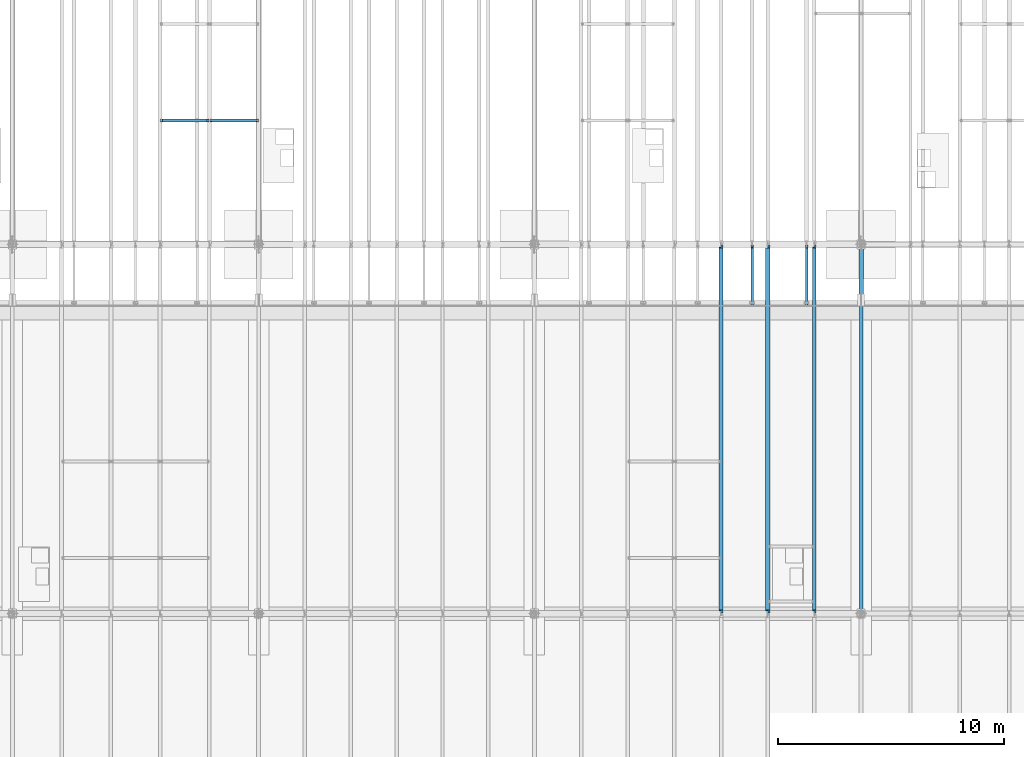
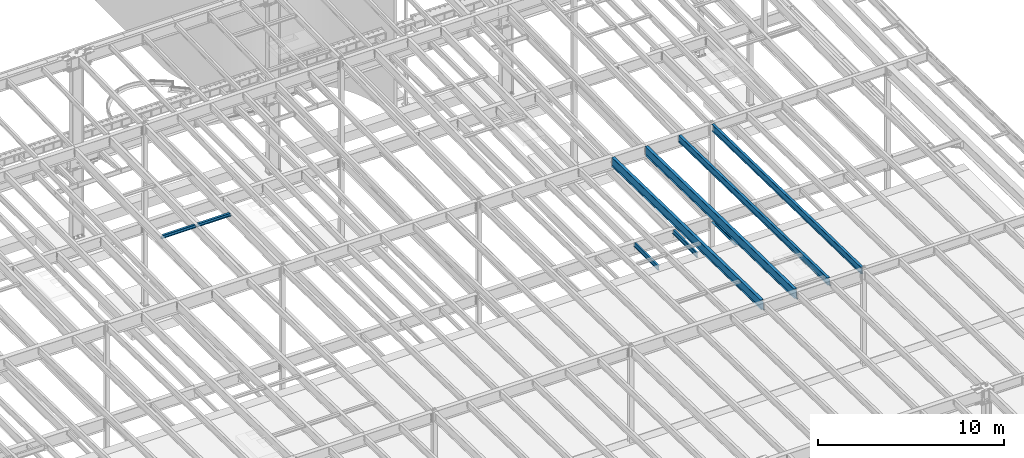
# One storey, part 1103 of 1763: 9 beams, 9 elements without a shape of their own.
"""IFC2X3 building model written with IfcOpenShell, lengths in millimetres."""

from ifc_helpers import new_model, si_unit, frame, origin_with_axes, place, context, subcontext, project, spatial, faceted_brep, material, type_object, element, aggregate, save


model = new_model("IFC2X3")

# Units and contexts
model_context = context("Model", 3, precision=1e-05, world=origin_with_axes())
body_context = subcontext(model_context, "Body", "Model", "MODEL_VIEW")
ifc_project = project(units=[si_unit("LENGTHUNIT", "METRE", prefix="MILLI"), si_unit("AREAUNIT", "SQUARE_METRE"), si_unit("VOLUMEUNIT", "CUBIC_METRE"), si_unit("MASSUNIT", "GRAM", prefix="KILO"), si_unit("TIMEUNIT", "SECOND"), si_unit("PLANEANGLEUNIT", "RADIAN"), si_unit("SOLIDANGLEUNIT", "STERADIAN"), si_unit("THERMODYNAMICTEMPERATUREUNIT", "DEGREE_CELSIUS"), si_unit("LUMINOUSINTENSITYUNIT", "LUMEN")], contexts=[model_context])

# Site, building, storey
site_placement = place(None, origin_with_axes())
site = spatial("IfcSite", under=ifc_project, at=site_placement, CompositionType="ELEMENT")
building_placement = place(site_placement, origin_with_axes())
building = spatial("IfcBuilding", under=site, at=building_placement, Name="Undefined", CompositionType="ELEMENT")
storey_placement = place(building_placement, origin_with_axes())
storey = spatial("IfcBuildingStorey", under=building, at=storey_placement, Name="Undefined", CompositionType="ELEMENT", Elevation=0.0)

# Assembly, beam
assembly_1_placement = place(storey_placement, origin_with_axes())
assembly_1 = element("IfcElementAssembly", 1, at=assembly_1_placement, inside=storey, Name="BEAM", AssemblyPlace="NOTDEFINED", PredefinedType="RIGID_FRAME")
ifc_material = material(Name="STEEL/A992")
beam_type_1 = type_object("IfcBeamType", Name="W8X18", PredefinedType="NOTDEFINED")
beam_1_placement = place(assembly_1_placement, frame((-65953.0772736983, 35509.2, 11300.6242220873), z_axis=(0.0, 0.0, 1.0), x_axis=(1.0, 0.0, 0.0)))
beam_1 = element("IfcBeam", 2, at=beam_1_placement, type_object=beam_type_1, material=ifc_material, Name="BEAM", ObjectType="W8X18", context=body_context, shape_type="Brep", body=[
    faceted_brep([(2083.02724382307, -3.17499999999927, 68.5472455037416), (2083.02724382307, 3.17499999999927, 68.5472455037416), (2082.16625903222, 3.17499999999927, 69.8358003002977), (2082.16625903222, -3.17499999999927, 69.8358003002977), (2087.14742029124, -3.17499999999927, 65.7942316032641), (2087.14742029124, 3.17499999999927, 65.7942316032641), (2092.00749980928, -3.17499999999927, 64.8275016806765), (2092.00749980928, 3.17499999999927, 64.8275016806765), (2161.85750000001, -3.17499999999927, 64.8275016806765), (2161.85750000001, 3.17499999999927, 64.8275016806765), (2081.43974687482, -3.17499999999927, 70.3212402040699), (2081.43974687482, 3.17499999999927, 70.3212402040699), (2078.68673297434, 3.17499999999927, 74.4414166722236), (2078.68673297434, -3.17499999999927, 74.4414166722236), (2077.72000305176, 3.17499999999927, 79.30149619027), (2077.72000305176, -3.17499999999927, 79.30149619027), (101.599996948244, 3.17500000000018, 95.25), (101.599996948244, 66.6750000000002, 95.25), (2077.72000305177, 66.6749999999993, 95.25), (2077.72000305177, 3.17499999999927, 95.25), (101.599996948244, -66.6750000000002, 103.1875), (101.599996948244, -66.6750000000002, 95.25), (2077.72000305177, -66.6749999999993, 95.25), (2077.72000305177, -66.6749999999993, 103.1875), (101.599996948244, 66.6750000000002, 103.1875), (2077.72000305177, 66.6749999999993, 103.1875), (2077.72000305177, -3.17499999999927, 95.25), (101.599996948244, -3.17500000000018, 95.25), (101.599996948236, 3.17499999999927, 79.301496189446), (101.599996948236, -3.17499999999927, 79.301496189446), (100.633267025652, 3.17499999999927, 74.4414166713996), (100.633267025652, -3.17499999999927, 74.4414166713996), (97.8802531251713, 3.17499999999927, 70.3212402032459), (97.8802531251713, -3.17499999999927, 70.3212402032459), (97.153740969894, 3.17499999999927, 69.8358003008998), (97.153740969894, -3.17499999999927, 69.8358003008998), (96.2927561769247, 3.17500000000018, 68.5472454911378), (96.2927561769247, -3.17500000000018, 68.5472454911378), (92.1725797087711, 3.17500000000018, 65.7942315906603), (92.1725797087711, -3.17500000000018, 65.7942315906603), (87.3125001907247, 3.17500000000018, 64.8275016680727), (87.3125001907247, -3.17500000000018, 64.8275016680727), (17.4624999999905, 3.17500000000018, 64.8275016680727), (17.4624999999905, -3.17500000000018, 64.8275016680727), (17.4624999999905, 3.17500000000018, -95.25), (17.4624999999905, 66.6750000000002, -95.25), (17.4624999999905, 66.6750000000002, -103.1875), (17.4624999999905, -66.6750000000002, -103.1875), (17.4624999999905, -66.6750000000002, -95.25), (17.4624999999905, -3.17500000000018, -95.25), (2161.85750000001, 3.17499999999927, -95.25), (2161.85750000001, 66.6749999999993, -95.25), (2161.85750000001, 66.6749999999993, -103.1875), (2161.85750000001, -66.6749999999993, -103.1875), (2161.85750000001, -66.6749999999993, -95.25), (2161.85750000001, -3.17499999999927, -95.25)], [[[0, 1, 2, 3]], [[4, 5, 1, 0]], [[6, 7, 5, 4]], [[8, 9, 7, 6]], [[10, 11, 12, 13]], [[13, 12, 14, 15]], [[16, 17, 18, 19]], [[20, 21, 22, 23]], [[24, 20, 23, 25]], [[17, 24, 25, 18]], [[23, 22, 26, 15, 14, 19, 18, 25]], [[21, 27, 26, 22]], [[20, 24, 17, 16, 28, 29, 27, 21]], [[29, 28, 30, 31]], [[31, 30, 32, 33]], [[33, 32, 34, 35]], [[35, 34, 36, 37]], [[37, 36, 38, 39]], [[39, 38, 40, 41]], [[41, 40, 42, 43]], [[44, 45, 46, 47, 48, 49, 43, 42]], [[45, 44, 50, 51]], [[46, 45, 51, 52]], [[47, 46, 52, 53]], [[48, 47, 53, 54]], [[49, 48, 54, 55]], [[4, 0, 3, 10, 13, 15, 26, 27, 29, 31, 33, 35, 37, 39, 41, 43, 49, 55, 8, 6]], [[11, 10, 3, 2]], [[50, 44, 42, 40, 38, 36, 34, 32, 30, 28, 16, 19, 14, 12, 11, 2, 1, 5, 7, 9]], [[55, 54, 53, 52, 51, 50, 9, 8]]]),
])
aggregate(assembly_1, [beam_1])

assembly_2_placement = place(storey_placement, origin_with_axes())
assembly_2 = element("IfcElementAssembly", 3, at=assembly_2_placement, inside=storey, Name="BEAM", AssemblyPlace="NOTDEFINED", PredefinedType="RIGID_FRAME")
beam_2_placement = place(assembly_2_placement, frame((-63773.7572736983, 35509.2, 11300.6242220873), z_axis=(0.0, 0.0, 1.0), x_axis=(1.0, 0.0, 0.0)))
beam_2 = element("IfcBeam", 4, at=beam_2_placement, type_object=beam_type_1, material=ifc_material, Name="BEAM", ObjectType="W8X18", context=body_context, shape_type="Brep", body=[
    faceted_brep([(2083.02724382307, -3.17499999999927, 68.5472455037416), (2083.02724382307, 3.17499999999927, 68.5472455037416), (2082.16625903222, 3.17499999999927, 69.8358003002977), (2082.16625903222, -3.17499999999927, 69.8358003002977), (2087.14742029124, -3.17499999999927, 65.7942316032641), (2087.14742029124, 3.17499999999927, 65.7942316032641), (2092.00749980928, -3.17499999999927, 64.8275016806765), (2092.00749980928, 3.17499999999927, 64.8275016806765), (2161.85750000001, -3.17499999999927, 64.8275016806765), (2161.85750000001, 3.17499999999927, 64.8275016806765), (2081.43974687482, -3.17499999999927, 70.3212402040699), (2081.43974687482, 3.17499999999927, 70.3212402040699), (2078.68673297434, 3.17499999999927, 74.4414166722236), (2078.68673297434, -3.17499999999927, 74.4414166722236), (2077.72000305176, 3.17499999999927, 79.30149619027), (2077.72000305176, -3.17499999999927, 79.30149619027), (101.599996948244, 3.17500000000018, 95.25), (101.599996948244, 66.6750000000002, 95.25), (2077.72000305177, 66.6749999999993, 95.25), (2077.72000305177, 3.17499999999927, 95.25), (101.599996948244, -66.6750000000002, 103.1875), (101.599996948244, -66.6750000000002, 95.25), (2077.72000305177, -66.6749999999993, 95.25), (2077.72000305177, -66.6749999999993, 103.1875), (101.599996948244, 66.6750000000002, 103.1875), (2077.72000305177, 66.6749999999993, 103.1875), (2077.72000305177, -3.17499999999927, 95.25), (101.599996948244, -3.17500000000018, 95.25), (101.599996948236, 3.17499999999927, 79.301496189446), (101.599996948236, -3.17499999999927, 79.301496189446), (100.633267025652, 3.17499999999927, 74.4414166713996), (100.633267025652, -3.17499999999927, 74.4414166713996), (97.8802531251713, 3.17499999999927, 70.3212402032459), (97.8802531251713, -3.17499999999927, 70.3212402032459), (97.153740969894, 3.17499999999927, 69.8358003008998), (97.153740969894, -3.17499999999927, 69.8358003008998), (96.2927561769247, 3.17500000000018, 68.5472454911378), (96.2927561769247, -3.17500000000018, 68.5472454911378), (92.1725797087711, 3.17500000000018, 65.7942315906603), (92.1725797087711, -3.17500000000018, 65.7942315906603), (87.3125001907247, 3.17500000000018, 64.8275016680727), (87.3125001907247, -3.17500000000018, 64.8275016680727), (17.4624999999905, 3.17500000000018, 64.8275016680727), (17.4624999999905, -3.17500000000018, 64.8275016680727), (17.4624999999905, 3.17500000000018, -95.25), (17.4624999999905, 66.6750000000002, -95.25), (17.4624999999905, 66.6750000000002, -103.1875), (17.4624999999905, -66.6750000000002, -103.1875), (17.4624999999905, -66.6750000000002, -95.25), (17.4624999999905, -3.17500000000018, -95.25), (2161.85750000001, 3.17499999999927, -95.25), (2161.85750000001, 66.6749999999993, -95.25), (2161.85750000001, 66.6749999999993, -103.1875), (2161.85750000001, -66.6749999999993, -103.1875), (2161.85750000001, -66.6749999999993, -95.25), (2161.85750000001, -3.17499999999927, -95.25)], [[[0, 1, 2, 3]], [[4, 5, 1, 0]], [[6, 7, 5, 4]], [[8, 9, 7, 6]], [[10, 11, 12, 13]], [[13, 12, 14, 15]], [[16, 17, 18, 19]], [[20, 21, 22, 23]], [[24, 20, 23, 25]], [[17, 24, 25, 18]], [[23, 22, 26, 15, 14, 19, 18, 25]], [[21, 27, 26, 22]], [[20, 24, 17, 16, 28, 29, 27, 21]], [[29, 28, 30, 31]], [[31, 30, 32, 33]], [[33, 32, 34, 35]], [[35, 34, 36, 37]], [[37, 36, 38, 39]], [[39, 38, 40, 41]], [[41, 40, 42, 43]], [[44, 45, 46, 47, 48, 49, 43, 42]], [[45, 44, 50, 51]], [[46, 45, 51, 52]], [[47, 46, 52, 53]], [[48, 47, 53, 54]], [[49, 48, 54, 55]], [[4, 0, 3, 10, 13, 15, 26, 27, 29, 31, 33, 35, 37, 39, 41, 43, 49, 55, 8, 6]], [[11, 10, 3, 2]], [[50, 44, 42, 40, 38, 36, 34, 32, 30, 28, 16, 19, 14, 12, 11, 2, 1, 5, 7, 9]], [[55, 54, 53, 52, 51, 50, 9, 8]]]),
])
aggregate(assembly_2, [beam_2])

assembly_3_placement = place(storey_placement, origin_with_axes())
assembly_3 = element("IfcElementAssembly", 5, at=assembly_3_placement, inside=storey, Name="BEAM", AssemblyPlace="NOTDEFINED", PredefinedType="RIGID_FRAME")
beam_type_2 = type_object("IfcBeamType", Name="W12X16", PredefinedType="NOTDEFINED")
beam_3_placement = place(assembly_3_placement, frame((-37358.603940365, 27279.6, 5041.9), z_axis=(0.0, 0.0, 1.0), x_axis=(0.0, 1.0, 0.0)))
beam_3 = element("IfcBeam", 6, at=beam_3_placement, type_object=beam_type_2, material=ifc_material, Name="BEAM", ObjectType="W12X16", context=body_context, shape_type="Brep", body=[
    faceted_brep([(63.5000000000036, -3.17499999999927, -146.05), (63.5000000000036, -50.7999999999993, -146.05), (2723.35625, -50.8000000000029, -146.05), (2723.35625, -3.17500000000291, -146.05), (63.5000000000036, -50.7999999999993, -152.4), (2723.35625, -50.8000000000029, -152.4), (63.5000000000036, 50.7999999999993, -152.4), (2723.35625, 50.8000000000029, -152.4), (63.5000000000036, 50.7999999999993, -146.05), (63.5000000000036, 3.17499999999927, -146.05), (2723.35625, 3.17500000000291, -146.05), (2723.35625, 50.8000000000029, -146.05), (2723.35625, 3.17500000000291, 120.390001678466), (2723.35625, -3.17500000000291, 120.390001678466), (63.5000000000036, -3.17499999999927, 146.05), (63.5000000000036, -50.7999999999993, 146.05), (63.5000000000036, -50.7999999999993, 152.4), (63.5000000000036, 50.7999999999993, 152.4), (63.5000000000036, 50.7999999999993, 146.05), (63.5000000000036, 3.17499999999927, 146.05), (2583.65625, 50.8000000000029, 146.05), (2583.65625, 3.17500000000291, 146.05), (2583.65625, 3.17500000000291, 133.090001487732), (2584.62297992259, 3.17500000000291, 128.229921969686), (2587.37599382307, 3.17500000000291, 124.109745501532), (2591.49617029122, 3.17500000000291, 121.356731601054), (2596.35624980927, 3.17500000000291, 120.390001678466), (2584.62297992259, -3.17500000000291, 128.229921969686), (2583.65625, -3.17500000000291, 133.090001487732), (2587.37599382307, -3.17500000000291, 124.109745501532), (2591.49617029122, -3.17500000000291, 121.356731601054), (2596.35624980927, -3.17500000000291, 120.390001678466), (2583.65625, -3.17500000000291, 146.05), (2583.65625, -50.8000000000029, 146.05), (2583.65625, -50.8000000000029, 152.4), (2583.65625, 50.8000000000029, 152.4)], [[[0, 1, 2, 3]], [[1, 4, 5, 2]], [[4, 6, 7, 5]], [[8, 9, 10, 11]], [[3, 2, 5, 7, 11, 10, 12, 13]], [[6, 8, 11, 7]], [[4, 1, 0, 14, 15, 16, 17, 18, 19, 9, 8, 6]], [[19, 18, 20, 21]], [[10, 9, 19, 21, 22, 23, 24, 25, 26, 12]], [[27, 23, 22, 28]], [[29, 24, 23, 27]], [[30, 25, 24, 29]], [[31, 26, 25, 30]], [[13, 12, 26, 31]], [[30, 29, 27, 28, 32, 14, 0, 3, 13, 31]], [[15, 14, 32, 33]], [[16, 15, 33, 34]], [[17, 16, 34, 35]], [[18, 17, 35, 20]], [[34, 33, 32, 28, 22, 21, 20, 35]]]),
])
aggregate(assembly_3, [beam_3])

assembly_4_placement = place(storey_placement, origin_with_axes())
assembly_4 = element("IfcElementAssembly", 7, at=assembly_4_placement, inside=storey, Name="BEAM", AssemblyPlace="NOTDEFINED", PredefinedType="RIGID_FRAME")
beam_4_placement = place(assembly_4_placement, frame((-39767.3706070317, 27279.6, 5041.9), z_axis=(0.0, 0.0, 1.0), x_axis=(0.0, 1.0, 0.0)))
beam_4 = element("IfcBeam", 8, at=beam_4_placement, type_object=beam_type_2, material=ifc_material, Name="BEAM", ObjectType="W12X16", context=body_context, shape_type="Brep", body=[
    faceted_brep([(63.5000000000036, -3.17499999999927, -146.05), (63.5000000000036, -50.7999999999993, -146.05), (2723.35625, -50.8000000000029, -146.05), (2723.35625, -3.17500000000291, -146.05), (63.5000000000036, -50.7999999999993, -152.4), (2723.35625, -50.8000000000029, -152.4), (63.5000000000036, 50.7999999999993, -152.4), (2723.35625, 50.8000000000029, -152.4), (63.5000000000036, 50.7999999999993, -146.05), (63.5000000000036, 3.17499999999927, -146.05), (2723.35625, 3.17500000000291, -146.05), (2723.35625, 50.8000000000029, -146.05), (2723.35625, 3.17500000000291, 120.390001678466), (2723.35625, -3.17500000000291, 120.390001678466), (63.5000000000036, -3.17499999999927, 146.05), (63.5000000000036, -50.7999999999993, 146.05), (63.5000000000036, -50.7999999999993, 152.4), (63.5000000000036, 50.7999999999993, 152.4), (63.5000000000036, 50.7999999999993, 146.05), (63.5000000000036, 3.17499999999927, 146.05), (2583.65625, 50.8000000000029, 146.05), (2583.65625, 3.17500000000291, 146.05), (2583.65625, 3.17500000000291, 133.090001487732), (2584.62297992259, 3.17500000000291, 128.229921969686), (2587.37599382307, 3.17500000000291, 124.109745501532), (2591.49617029122, 3.17500000000291, 121.356731601054), (2596.35624980927, 3.17500000000291, 120.390001678466), (2584.62297992259, -3.17500000000291, 128.229921969686), (2583.65625, -3.17500000000291, 133.090001487732), (2587.37599382307, -3.17500000000291, 124.109745501532), (2591.49617029122, -3.17500000000291, 121.356731601054), (2596.35624980927, -3.17500000000291, 120.390001678466), (2583.65625, -3.17500000000291, 146.05), (2583.65625, -50.8000000000029, 146.05), (2583.65625, -50.8000000000029, 152.4), (2583.65625, 50.8000000000029, 152.4)], [[[0, 1, 2, 3]], [[1, 4, 5, 2]], [[4, 6, 7, 5]], [[8, 9, 10, 11]], [[3, 2, 5, 7, 11, 10, 12, 13]], [[6, 8, 11, 7]], [[4, 1, 0, 14, 15, 16, 17, 18, 19, 9, 8, 6]], [[19, 18, 20, 21]], [[10, 9, 19, 21, 22, 23, 24, 25, 26, 12]], [[27, 23, 22, 28]], [[29, 24, 23, 27]], [[30, 25, 24, 29]], [[31, 26, 25, 30]], [[13, 12, 26, 31]], [[30, 29, 27, 28, 32, 14, 0, 3, 13, 31]], [[15, 14, 32, 33]], [[16, 15, 33, 34]], [[17, 16, 34, 35]], [[18, 17, 35, 20]], [[34, 33, 32, 28, 22, 21, 20, 35]]]),
])
aggregate(assembly_4, [beam_4])

assembly_5_placement = place(storey_placement, origin_with_axes())
assembly_5 = element("IfcElementAssembly", 9, at=assembly_5_placement, inside=storey, Name="BEAM", AssemblyPlace="NOTDEFINED", PredefinedType="RIGID_FRAME")
beam_type_3 = type_object("IfcBeamType", Name="W18X40", PredefinedType="NOTDEFINED")
beam_5_placement = place(assembly_5_placement, frame((-37014.4944165555, 13685.8551307141, 11404.7768219843), z_axis=(0.0, 0.0209013539966291, 0.999781542838788), x_axis=(0.0, 0.999781542776098, -0.0209013569953182)))
beam_5 = element("IfcBeam", 10, at=beam_5_placement, type_object=beam_type_3, material=ifc_material, Name="BEAM", ObjectType="W18X40", context=body_context, shape_type="Brep", body=[
    faceted_brep([(132.544002095614, 4.26866853534011, -214.312499999889), (132.544002095599, 4.26882839031896, -227.012499999888), (29.339897632873, 4.26882972748717, -227.01250000019), (29.0743924101943, 4.26863241521642, -214.31250000018), (132.543992672528, 76.1999999999971, -214.312499999889), (132.543992672539, 76.1999999999971, -227.012499999888), (164.293992016979, -3.96875, 195.002501487832), (164.293992016979, 3.96875, 195.002501487832), (163.327262094397, 3.96875, 190.142421969791), (163.327262094397, -3.96875, 190.142421969791), (160.574248193921, 3.96875, 186.022245501637), (160.574248193921, -3.96875, 186.022245501637), (156.454071725771, 3.96875, 183.269231601158), (156.454071725771, -3.96875, 183.269231601158), (151.593992207727, 3.96875, 182.302501678567), (151.593992207727, -3.96875, 182.302501678567), (20.7827897637508, 3.96875, 182.30250167849), (20.7827897637508, -3.96875, 182.30250167849), (29.0743924101943, -3.96875, -214.31250000018), (16325.1468877506, -3.96875, -214.312499990354), (16316.8552846474, -3.96875, 182.302501822591), (16187.3164867041, -3.96875, 182.302501822514), (16182.456407186, -3.96875, 183.269231745098), (16178.3362307179, -3.96875, 186.022245645572), (16175.5832168174, -3.96875, 190.142422113722), (16174.6164868948, -3.96875, 195.002501631765), (16174.6164868948, -3.96875, 214.312500009495), (164.29399201697, -3.96875, 214.312500000067), (29.0743924101943, -76.1999999999971, -214.31250000018), (16325.1468877506, -76.1999999999971, -214.312499990354), (29.339897632873, -76.1999999999971, -227.01250000019), (16325.412392986, -76.1999999999971, -227.012499990351), (16225.4164838328, 4.26882845565706, -214.312499990412), (16225.4164838328, 4.26866860519658, -227.012499990411), (16225.4164773588, 76.1999999999971, -227.012499990409), (16225.4164773587, 76.1999999999971, -214.312499990414), (16325.412392986, 4.2686776052069, -227.012499990351), (16325.1468877506, 4.26883743175858, -214.312499990354), (16325.1468877506, 3.96875, -214.312499990354), (16316.8552846474, 3.96875, 182.302501822591), (16187.3164867041, 3.96875, 182.302501822514), (16182.456407186, 3.96875, 183.269231745098), (16178.3362307179, 3.96875, 186.022245645572), (16175.5832168174, 3.96875, 190.142422113722), (16174.6164868948, 3.96875, 195.002501631765), (16174.6164868948, -76.1999999999971, 227.01250000949), (16174.6164868948, -76.1999999999971, 214.312500009495), (16174.6164868948, 3.96875, 214.312500009495), (16174.6164868948, 76.1999999999971, 214.312500009495), (16174.6164868948, 76.1999999999971, 227.01250000949), (164.29399201697, 3.96875, 214.312500000067), (164.29399201697, 76.1999999999971, 214.312500000067), (164.293992016963, 76.1999999999971, 227.012500000064), (164.293992016963, -76.1999999999971, 227.012500000064), (164.29399201697, -76.1999999999971, 214.312500000067), (29.0743924101943, 3.96875, -214.31250000018)], [[[0, 1, 2, 3]], [[4, 5, 1, 0]], [[6, 7, 8, 9]], [[9, 8, 10, 11]], [[11, 10, 12, 13]], [[13, 12, 14, 15]], [[15, 14, 16, 17]], [[9, 11, 13, 15, 17, 18, 19, 20, 21, 22, 23, 24, 25, 26, 27, 6]], [[18, 28, 29, 19]], [[28, 30, 31, 29]], [[32, 33, 34, 35]], [[36, 33, 32, 37]], [[38, 39, 20, 19, 29, 31, 36, 37]], [[20, 39, 40, 21]], [[21, 40, 41, 22]], [[22, 41, 42, 23]], [[23, 42, 43, 24]], [[24, 43, 44, 25]], [[45, 46, 26, 25, 44, 47, 48, 49]], [[48, 47, 50, 51]], [[49, 48, 51, 52]], [[45, 49, 52, 53]], [[46, 45, 53, 54]], [[26, 46, 54, 27]], [[53, 52, 51, 50, 7, 6, 27, 54]], [[47, 44, 43, 42, 41, 40, 39, 38, 55, 16, 14, 12, 10, 8, 7, 50]], [[30, 28, 18, 17, 16, 55, 3, 2]], [[34, 33, 36, 31, 30, 2, 1, 5]], [[35, 34, 5, 4]], [[55, 38, 37, 32, 35, 4, 0, 3]]]),
])
aggregate(assembly_5, [beam_5])

assembly_6_placement = place(storey_placement, origin_with_axes())
assembly_6 = element("IfcElementAssembly", 11, at=assembly_6_placement, inside=storey, Name="BEAM", AssemblyPlace="NOTDEFINED", PredefinedType="RIGID_FRAME")
beam_6_placement = place(assembly_6_placement, frame((-34949.8372736984, 13685.8548242898, 11404.7988868453), z_axis=(0.0, 0.0209027059910768, 0.999781514573185), x_axis=(0.0, 0.999781514573184, -0.0209027059910808)))
beam_6 = element("IfcBeam", 12, at=beam_6_placement, type_object=beam_type_3, material=ifc_material, Name="BEAM", ObjectType="W18X40", context=body_context, shape_type="Brep", body=[
    faceted_brep([(149.22295429465, -76.1999999999971, -227.012499999968), (149.22295429465, 76.1999999999971, -227.012499999968), (16200.7674828319, 76.1999999999971, -227.012500012277), (16200.7674828319, -76.1999999999971, -227.012500012277), (148.957431915793, -76.1999999999971, -214.312499999975), (148.957431915793, -3.96875, -214.312499999975), (139.996051629378, -3.96875, 214.31249999976), (139.996051629378, -76.1999999999971, 214.31249999976), (139.730529250521, -76.1999999999971, 227.012499999752), (139.730529250521, 76.1999999999971, 227.012499999752), (139.996051629378, 76.1999999999971, 214.31249999976), (139.996051629378, 3.96875, 214.31249999976), (148.957431915793, 3.96875, -214.312499999975), (148.957431915793, 76.1999999999971, -214.312499999975), (16200.501960453, -76.1999999999971, -214.312500012285), (16200.501960453, -3.96875, -214.312500012285), (16191.5405801666, -3.96875, 214.312499987449), (16191.5405801666, -76.1999999999971, 214.312499987449), (16191.2750577878, -76.1999999999971, 227.012499987441), (16191.2750577878, 76.1999999999971, 227.012499987441), (16191.5405801666, 76.1999999999971, 214.312499987449), (16191.5405801666, 3.96875, 214.312499987449), (16200.501960453, 3.96875, -214.312500012285), (16200.501960453, 76.1999999999971, -214.312500012285)], [[[0, 1, 2, 3]], [[0, 4, 5, 6, 7, 8, 9, 10, 11, 12, 13, 1]], [[5, 4, 14, 15]], [[6, 5, 15, 16]], [[7, 6, 16, 17]], [[8, 7, 17, 18]], [[9, 8, 18, 19]], [[10, 9, 19, 20]], [[11, 10, 20, 21]], [[12, 11, 21, 22]], [[13, 12, 22, 23]], [[1, 13, 23, 2]], [[22, 21, 20, 19, 18, 17, 16, 15, 14, 3, 2, 23]], [[4, 0, 3, 14]]]),
])
aggregate(assembly_6, [beam_6])

assembly_7_placement = place(storey_placement, origin_with_axes())
assembly_7 = element("IfcElementAssembly", 13, at=assembly_7_placement, inside=storey, Name="BEAM", AssemblyPlace="NOTDEFINED", PredefinedType="RIGID_FRAME")
beam_type_4 = type_object("IfcBeamType", Name="W24X55", PredefinedType="NOTDEFINED")
beam_7_placement = place(assembly_7_placement, frame((-41143.8087022698, 13684.3288091446, 11331.7677748226), z_axis=(0.0, 0.0209013539966291, 0.999781542838788), x_axis=(0.0, 0.999781542776098, -0.0209013569953182)))
beam_7 = element("IfcBeam", 14, at=beam_7_placement, type_object=beam_type_4, material=ifc_material, Name="BEAM", ObjectType="W24X55", context=body_context, shape_type="Brep", body=[
    faceted_brep([(134.070659533922, 5.06239015424217, -287.337499999876), (134.070659533891, 5.06260677571845, -300.037499999875), (32.3932082812735, 5.06259254094039, -300.037499999935), (32.127703045895, 5.06237588229124, -287.337499999938), (134.070647796716, 88.9000000000015, -287.337499999878), (134.070647796721, 88.9000000000015, -300.037499999875), (165.820647095326, -4.76249999999709, 268.027501487795), (165.820647095326, 4.76249999999709, 268.027501487795), (164.853917172741, 4.76249999999709, 263.167421969751), (164.853917172741, -4.76249999999709, 263.167421969751), (162.100903272267, 4.76249999999709, 259.047245501597), (162.100903272267, -4.76249999999709, 259.047245501597), (157.980726804117, 4.76249999999709, 256.294231601119), (157.980726804117, -4.76249999999709, 256.294231601119), (153.120647286072, 4.76249999999709, 255.327501678528), (153.120647286072, -4.76249999999709, 255.327501678528), (20.7827897386833, 4.76249999999709, 255.32750167845), (20.7827897386833, -4.76249999999709, 255.32750167845), (32.127703045895, -4.76249999999709, -287.337499999938), (16328.2001979324, -4.76249999999709, -287.337499990341), (16316.8552846223, -4.76249999999709, 255.32750182257), (16188.8431417824, -4.76249999999709, 255.327501822494), (16183.9830622644, -4.76249999999709, 256.29423174508), (16179.8628857962, -4.76249999999709, 259.047245645552), (16177.1098718957, -4.76249999999709, 263.167422113704), (16176.1431419731, -4.76249999999709, 268.027501631745), (16176.1431419731, -4.76249999999709, 287.337500009484), (165.820647095314, -4.76249999999709, 287.337500000056), (32.127703045895, -88.9000000000015, -287.337499999938), (16328.2001979324, -88.9000000000015, -287.337499990341), (32.3932082812735, -88.9000000000015, -300.037499999935), (16328.4657031678, -88.9000000000015, -300.037499990338), (16226.943138802, 5.06260682461289, -287.337499990401), (16226.943138802, 5.06239020794601, -300.037499990398), (16226.9431320109, 88.9000000000015, -300.037499990398), (16226.9431320109, 88.9000000000015, -287.337499990401), (16299.8693796049, 5.06250000000728, -287.337499990357), (16228.1976692106, 5.06250000000728, -288.83586332407), (16228.1663445405, 5.06250000000728, -287.337499990399), (16328.4657031678, 5.06239843160438, -300.037499990338), (16328.2001979324, 5.06261502674897, -287.337499990341), (16328.2001979324, 4.76249999999709, -287.337499990341), (16316.8552846223, 4.76249999999709, 255.32750182257), (16188.8431417824, 4.76249999999709, 255.327501822494), (16183.9830622644, 4.76249999999709, 256.29423174508), (16179.8628857962, 4.76249999999709, 259.047245645552), (16177.1098718957, 4.76249999999709, 263.167422113704), (16176.1431419731, 4.76249999999709, 268.027501631745), (16176.1431419731, -88.9000000000015, 300.037500009483), (16176.1431419731, -88.9000000000015, 287.337500009484), (16176.1431419731, 4.76249999999709, 287.337500009484), (16176.1431419731, 88.9000000000015, 287.337500009484), (16176.1431419731, 88.9000000000015, 300.037500009483), (165.820647095314, 4.76249999999709, 287.337500000056), (165.820647095314, 88.9000000000015, 287.337500000056), (165.820647095305, 88.9000000000015, 300.037500000057), (165.820647095305, -88.9000000000015, 300.037500000057), (165.820647095314, -88.9000000000015, 287.337500000056), (32.127703045895, 4.76249999999709, -287.337499999938)], [[[0, 1, 2, 3]], [[4, 5, 1, 0]], [[6, 7, 8, 9]], [[9, 8, 10, 11]], [[11, 10, 12, 13]], [[13, 12, 14, 15]], [[15, 14, 16, 17]], [[9, 11, 13, 15, 17, 18, 19, 20, 21, 22, 23, 24, 25, 26, 27, 6]], [[18, 28, 29, 19]], [[28, 30, 31, 29]], [[32, 33, 34, 35]], [[36, 37, 38]], [[39, 33, 32, 38, 37, 36, 40]], [[41, 42, 20, 19, 29, 31, 39, 40]], [[20, 42, 43, 21]], [[21, 43, 44, 22]], [[22, 44, 45, 23]], [[23, 45, 46, 24]], [[24, 46, 47, 25]], [[48, 49, 26, 25, 47, 50, 51, 52]], [[51, 50, 53, 54]], [[52, 51, 54, 55]], [[48, 52, 55, 56]], [[49, 48, 56, 57]], [[26, 49, 57, 27]], [[56, 55, 54, 53, 7, 6, 27, 57]], [[50, 47, 46, 45, 44, 43, 42, 41, 58, 16, 14, 12, 10, 8, 7, 53]], [[30, 28, 18, 17, 16, 58, 3, 2]], [[34, 33, 39, 31, 30, 2, 1, 5]], [[35, 34, 5, 4]], [[58, 41, 40, 36, 38, 32, 35, 4, 0, 3]]]),
])
aggregate(assembly_7, [beam_7])

assembly_8_placement = place(storey_placement, origin_with_axes())
assembly_8 = element("IfcElementAssembly", 15, at=assembly_8_placement, inside=storey, Name="BEAM", AssemblyPlace="NOTDEFINED", PredefinedType="RIGID_FRAME")
beam_8_placement = place(assembly_8_placement, frame((-39079.1515594127, 13684.3288091094, 11331.7677748225), z_axis=(0.0, 0.0209013539966291, 0.999781542838788), x_axis=(0.0, 0.999781542776098, -0.0209013569953182)))
beam_8 = element("IfcBeam", 16, at=beam_8_placement, type_object=beam_type_4, material=ifc_material, Name="BEAM", ObjectType="W24X55", context=body_context, shape_type="Brep", body=[
    faceted_brep([(134.070659533922, 5.06239015424217, -287.337499999876), (134.070659533891, 5.06260677571845, -300.037499999875), (32.3932082812735, 5.06259254094039, -300.037499999935), (32.127703045895, 5.06237588229124, -287.337499999938), (134.070647796716, 88.9000000000015, -287.337499999878), (134.070647796721, 88.9000000000015, -300.037499999875), (165.820647095326, -4.76249999999709, 268.027501487795), (165.820647095326, 4.76249999999709, 268.027501487795), (164.853917172741, 4.76249999999709, 263.167421969751), (164.853917172741, -4.76249999999709, 263.167421969751), (162.100903272267, 4.76249999999709, 259.047245501597), (162.100903272267, -4.76249999999709, 259.047245501597), (157.980726804117, 4.76249999999709, 256.294231601119), (157.980726804117, -4.76249999999709, 256.294231601119), (153.120647286072, 4.76249999999709, 255.327501678528), (153.120647286072, -4.76249999999709, 255.327501678528), (20.7827897386833, 4.76249999999709, 255.32750167845), (20.7827897386833, -4.76249999999709, 255.32750167845), (32.127703045895, -4.76249999999709, -287.337499999938), (16328.2001979324, -4.76249999999709, -287.337499990341), (16316.988037273, -4.76249999999709, 248.977501822537), (16188.8431418176, -4.76249999999709, 248.977501822461), (16183.9830622995, -4.76249999999709, 249.944231745047), (16179.8628858314, -4.76249999999709, 252.697245645521), (16177.1098719309, -4.76249999999709, 256.817422113672), (16176.1431420083, -4.76249999999709, 261.677501631713), (16176.1431419731, -4.76249999999709, 287.337500009484), (165.820647095314, -4.76249999999709, 287.337500000056), (32.127703045895, -88.9000000000015, -287.337499999938), (16328.2001979324, -88.9000000000015, -287.337499990341), (32.3932082812735, -88.9000000000015, -300.037499999935), (16328.4657031678, -88.9000000000015, -300.037499990338), (16176.143133544, 5.06260677496175, -287.337499990432), (16176.143133544, 5.06239015274332, -300.037499990429), (16176.143128933, 88.9000000000015, -300.037499990429), (16176.143128933, 88.9000000000015, -287.33749999043), (16299.8693796049, 5.06250000000728, -287.337499990357), (16228.1976692106, 5.06250000000728, -288.83586332407), (16228.1663445405, 5.06250000000728, -287.337499990399), (16328.4657031678, 5.06239843160438, -300.037499990338), (16328.2001979324, 5.06261502674897, -287.337499990341), (16328.2001979324, 4.76249999999709, -287.337499990341), (16316.988037273, 4.76249999999709, 248.977501822537), (16188.8431418176, 4.76249999999709, 248.977501822461), (16183.9830622995, 4.76249999999709, 249.944231745047), (16179.8628858314, 4.76249999999709, 252.697245645521), (16177.1098719309, 4.76249999999709, 256.817422113672), (16176.1431420083, 4.76249999999709, 261.677501631713), (16176.1431419731, -88.9000000000015, 300.037500009483), (16176.1431419731, -88.9000000000015, 287.337500009484), (16176.1431419731, 4.76249999999709, 287.337500009484), (16176.1431419731, 88.9000000000015, 287.337500009484), (16176.1431419731, 88.9000000000015, 300.037500009483), (165.820647095314, 4.76249999999709, 287.337500000056), (165.820647095314, 88.9000000000015, 287.337500000056), (165.820647095305, 88.9000000000015, 300.037500000057), (165.820647095305, -88.9000000000015, 300.037500000057), (165.820647095314, -88.9000000000015, 287.337500000056), (32.127703045895, 4.76249999999709, -287.337499999938)], [[[0, 1, 2, 3]], [[4, 5, 1, 0]], [[6, 7, 8, 9]], [[9, 8, 10, 11]], [[11, 10, 12, 13]], [[13, 12, 14, 15]], [[15, 14, 16, 17]], [[9, 11, 13, 15, 17, 18, 19, 20, 21, 22, 23, 24, 25, 26, 27, 6]], [[18, 28, 29, 19]], [[28, 30, 31, 29]], [[32, 33, 34, 35]], [[36, 37, 38]], [[39, 33, 32, 38, 37, 36, 40]], [[41, 42, 20, 19, 29, 31, 39, 40]], [[20, 42, 43, 21]], [[21, 43, 44, 22]], [[22, 44, 45, 23]], [[23, 45, 46, 24]], [[24, 46, 47, 25]], [[48, 49, 26, 25, 47, 50, 51, 52]], [[51, 50, 53, 54]], [[52, 51, 54, 55]], [[48, 52, 55, 56]], [[49, 48, 56, 57]], [[26, 49, 57, 27]], [[56, 55, 54, 53, 7, 6, 27, 57]], [[50, 47, 46, 45, 44, 43, 42, 41, 58, 16, 14, 12, 10, 8, 7, 53]], [[30, 28, 18, 17, 16, 58, 3, 2]], [[34, 33, 39, 31, 30, 2, 1, 5]], [[35, 34, 5, 4]], [[58, 41, 40, 36, 38, 32, 35, 4, 0, 3]]]),
])
aggregate(assembly_8, [beam_8])

assembly_9_placement = place(storey_placement, origin_with_axes())
assembly_9 = element("IfcElementAssembly", 17, at=assembly_9_placement, inside=storey, Name="BEAM", AssemblyPlace="NOTDEFINED", PredefinedType="RIGID_FRAME")
beam_type_5 = type_object("IfcBeamType", Name="W12X50", PredefinedType="NOTDEFINED")
beam_9_placement = place(assembly_9_placement, frame((-34949.8372736984, 27279.6, 5038.725), z_axis=(0.0, 0.0, 1.0), x_axis=(0.0, 1.0, 0.0)))
beam_9 = element("IfcBeam", 18, at=beam_9_placement, type_object=beam_type_5, material=ifc_material, Name="BEAM", ObjectType="W12X50", context=body_context, shape_type="Brep", body=[
    faceted_brep([(50.7999999999993, -103.1875, -139.7), (50.7999999999993, -103.1875, -155.575), (2598.7375, -103.1875, -155.575), (2598.7375, -103.1875, -139.7), (50.7999999999993, -4.76250000000073, -139.7), (2598.7375, -4.76249999999709, -139.7), (50.7999999999993, -4.76250000000073, 139.7), (2598.7375, -4.76249999999709, 139.7), (50.7999999999993, -103.1875, 139.7), (2598.7375, -103.1875, 139.7), (50.7999999999993, -103.1875, 155.575), (2598.7375, -103.1875, 155.575), (50.7999999999993, 103.1875, 155.575), (2598.7375, 103.1875, 155.575), (50.7999999999993, 103.1875, 139.7), (2598.7375, 103.1875, 139.7), (50.7999999999993, 4.76250000000073, 139.7), (2598.7375, 4.76249999999709, 139.7), (50.7999999999993, 4.76250000000073, -139.7), (2598.7375, 4.76249999999709, -139.7), (50.7999999999993, 103.1875, -139.7), (2598.7375, 103.1875, -139.7), (50.7999999999993, 103.1875, -155.575), (2598.7375, 103.1875, -155.575)], [[[0, 1, 2, 3]], [[4, 0, 3, 5]], [[6, 4, 5, 7]], [[8, 6, 7, 9]], [[10, 8, 9, 11]], [[12, 10, 11, 13]], [[14, 12, 13, 15]], [[16, 14, 15, 17]], [[18, 16, 17, 19]], [[20, 18, 19, 21]], [[1, 0, 4, 6, 8, 10, 12, 14, 16, 18, 20, 22]], [[1, 22, 23, 2]], [[19, 17, 15, 13, 11, 9, 7, 5, 3, 2, 23, 21]], [[22, 20, 21, 23]]]),
])
aggregate(assembly_9, [beam_9])

save(model, "model.ifc")
